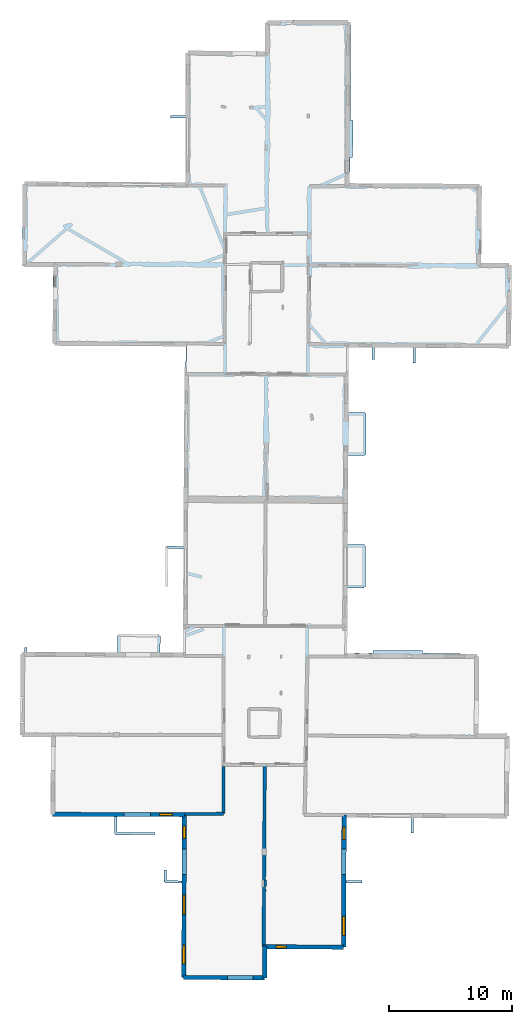
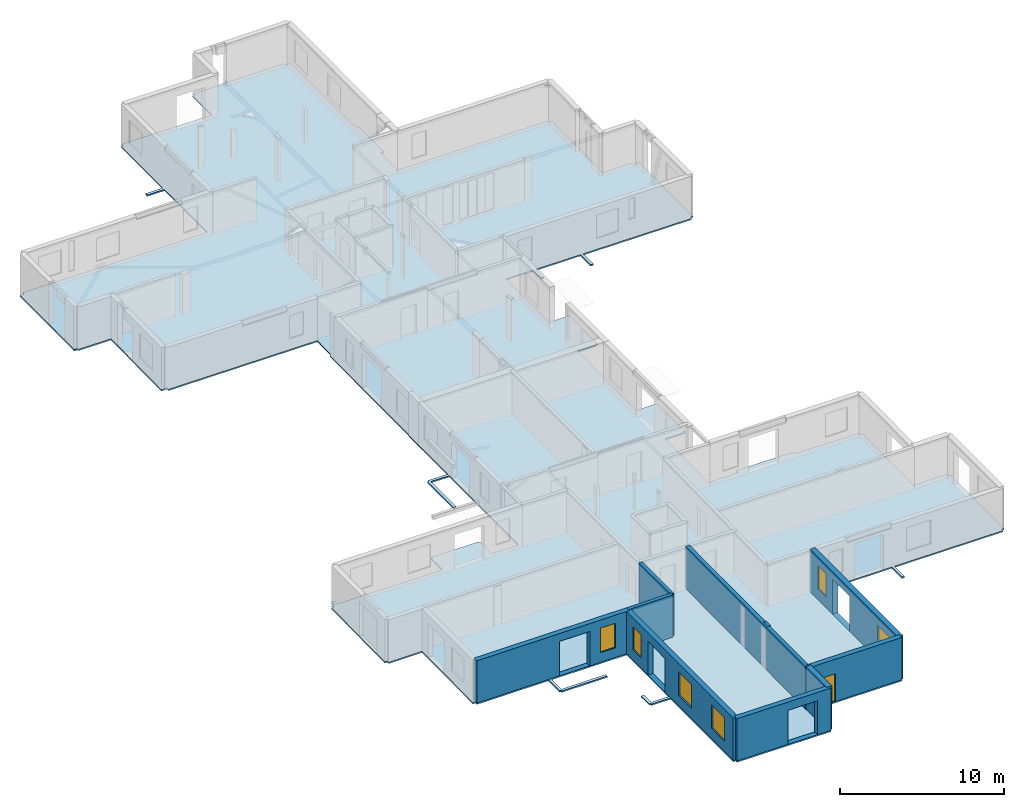
# One storey, part 2 of 14: 10 walls, 7 windows, 1 slab, 11 openings.
"""IFC2X3 building model written with IfcOpenShell, lengths in metres."""

from ifc_helpers import new_model, entity, si_unit, converted_unit, derived_unit, direction, frame, frame_2d, origin, origin_2d_with_axis, place, context, subcontext, project, spatial, polyline, rectangle, outline, extrude, source, transform, mapped, material, layer, layer_set, layer_usage, type_object, type_shapes, element, fill, save


model = new_model("IFC2X3")

# Units and contexts
model_context = context("Model", 3, precision=1e-05, world=origin(), true_north=direction((0.0, 1.0)))
body_context = subcontext(model_context, "Body", "Model", "MODEL_VIEW")
ifc_project = project(units=[si_unit("LENGTHUNIT", "METRE"), si_unit("AREAUNIT", "SQUARE_METRE"), si_unit("VOLUMEUNIT", "CUBIC_METRE"), converted_unit("PLANEANGLEUNIT", "DEGREE", entity("IfcRatioMeasure", 0.0174532925199433), si_unit("PLANEANGLEUNIT", "RADIAN"), dimensions=[0, 0, 0, 0, 0, 0, 0]), si_unit("MASSUNIT", "GRAM", prefix="KILO"), derived_unit("MASSDENSITYUNIT", [(si_unit("MASSUNIT", "GRAM", prefix="KILO"), 1), (si_unit("LENGTHUNIT", "METRE"), -3)]), derived_unit("MOMENTOFINERTIAUNIT", [(si_unit("LENGTHUNIT", "METRE"), 4)]), si_unit("TIMEUNIT", "SECOND"), si_unit("FREQUENCYUNIT", "HERTZ"), si_unit("THERMODYNAMICTEMPERATUREUNIT", "DEGREE_CELSIUS"), derived_unit("THERMALTRANSMITTANCEUNIT", [(si_unit("MASSUNIT", "GRAM", prefix="KILO"), 1), (si_unit("THERMODYNAMICTEMPERATUREUNIT", "KELVIN"), -1), (si_unit("TIMEUNIT", "SECOND"), -3)]), derived_unit("VOLUMETRICFLOWRATEUNIT", [(si_unit("LENGTHUNIT", "METRE"), 3), (si_unit("TIMEUNIT", "SECOND"), -1)]), si_unit("ELECTRICCURRENTUNIT", "AMPERE"), si_unit("ELECTRICVOLTAGEUNIT", "VOLT"), si_unit("POWERUNIT", "WATT"), si_unit("FORCEUNIT", "NEWTON", prefix="KILO"), si_unit("ILLUMINANCEUNIT", "LUX"), si_unit("LUMINOUSFLUXUNIT", "LUMEN"), si_unit("LUMINOUSINTENSITYUNIT", "CANDELA"), derived_unit("USERDEFINED", [(si_unit("MASSUNIT", "GRAM", prefix="KILO"), -1), (si_unit("LENGTHUNIT", "METRE"), -2), (si_unit("TIMEUNIT", "SECOND"), 3), (si_unit("LUMINOUSFLUXUNIT", "LUMEN"), 1)]), derived_unit("LINEARVELOCITYUNIT", [(si_unit("LENGTHUNIT", "METRE"), 1), (si_unit("TIMEUNIT", "SECOND"), -1)]), si_unit("PRESSUREUNIT", "PASCAL"), derived_unit("USERDEFINED", [(si_unit("LENGTHUNIT", "METRE"), -2), (si_unit("MASSUNIT", "GRAM", prefix="KILO"), 1), (si_unit("TIMEUNIT", "SECOND"), -2)]), derived_unit("LINEARFORCEUNIT", [(si_unit("MASSUNIT", "GRAM", prefix="KILO"), 1), (si_unit("LENGTHUNIT", "METRE"), 1), (si_unit("TIMEUNIT", "SECOND"), -2), (si_unit("LENGTHUNIT", "METRE"), -1)]), derived_unit("PLANARFORCEUNIT", [(si_unit("MASSUNIT", "GRAM", prefix="KILO"), 1), (si_unit("LENGTHUNIT", "METRE"), 1), (si_unit("TIMEUNIT", "SECOND"), -2), (si_unit("LENGTHUNIT", "METRE"), -2)])], contexts=[model_context])

# Site, building, storey
placement = place(None, origin())
site = spatial("IfcSite", under=ifc_project, at=placement, CompositionType="ELEMENT")
building = spatial("IfcBuilding", under=site, at=placement, CompositionType="ELEMENT")
storey_placement = place(placement, frame((0.0, 0.0, 8.83152770996094)))
storey = spatial("IfcBuildingStorey", under=building, at=storey_placement, Name="Level 4", CompositionType="ELEMENT", Elevation=8.83152770996094)

# Slab
ifc_material_1 = material(Name="Floor default")
ifc_layer_1 = layer(ifc_material_1, 0.1)
ifc_layer_set_1 = layer_set([ifc_layer_1], Name="Floor : 100mm")
ifc_layer_usage_1 = layer_usage(ifc_layer_set_1, "AXIS3", "POSITIVE", 0.0)
slab_type = type_object("IfcSlabType", Name="Floor : 100mm", PredefinedType="FLOOR")
slab_placement = place(storey_placement, origin())
element("IfcSlab", 1, at=slab_placement, inside=storey, type_object=slab_type, material=ifc_layer_usage_1, Name="Floor : 100mm", ObjectType="Floor : 100mm", PredefinedType="FLOOR", context=body_context, shape_type="SweptSolid", body=[
    extrude(outline(polyline([(-13.6808433532715, 19.4466152191162), (-13.5058479309082, 19.4453754425049), (-13.5059690475464, 19.2753753662109), (-11.161319732666, 19.2737121582031), (-11.2087287902832, 13.0091133117676), (-11.0337352752686, 13.0077896118164), (-11.0340738296509, 12.8327903747559), (-6.01071310043335, 12.8230762481689), (-6.01613569259644, 11.4494981765747), (-5.91613674163818, 11.4491033554077), (-5.91599750518799, 11.349102973938), (-2.7152214050293, 11.3535594940186), (-2.71549987792969, 11.5535593032837), (-5.81574058532715, 11.5492429733276), (-5.81071329116821, 12.8226900100708), (-0.506346702575684, 12.8124332427979), (-0.527259826660156, 7.61373710632324), (-1.77434730529785, 7.61762619018555), (-1.77778148651123, 8.5024995803833), (-1.97777938842773, 8.50172328948975), (-1.97396087646484, 7.51754903793335), (-1.87396144866943, 7.51793718338013), (-1.8742733001709, 7.41793775558472), (-0.528064727783203, 7.41373920440674), (-0.558828353881836, -0.233521282672882), (-0.383831024169922, -0.234224960207939), (-0.384821891784668, -0.409220635890961), (6.19634246826172, -0.446501553058624), (6.19733238220215, -0.271504580974579), (6.38232803344727, -0.270634293556213), (6.37127304077148, 2.07948136329651), (12.6121635437012, 2.04604291915894), (12.6131000518799, 2.22103953361511), (12.7981014251709, 2.22057437896729), (12.8112106323242, 7.43528461456299), (14.0985069274902, 7.44877481460571), (14.0964088439941, 7.64876365661621), (12.8117141723633, 7.63529968261719), (12.8245410919189, 12.7380781173706), (18.0702667236328, 12.7167844772339), (18.0606250762939, 11.4745321273804), (18.2606182098389, 11.4729804992676), (18.270263671875, 12.7159719467163), (25.8560485839844, 12.6851787567139), (25.8567581176758, 12.8601760864258), (26.0417556762695, 12.8593769073486), (26.0699653625488, 19.3851890563965), (25.8849601745605, 19.3859901428223), (25.883472442627, 19.5959796905518), (23.567928314209, 19.5795650482178), (23.6191291809082, 25.8393383026123), (23.434139251709, 25.8408508300781), (23.4348793029785, 26.0308494567871), (19.0079917907715, 26.1012115478516), (19.0089912414551, 26.3012084960938), (14.9984302520752, 26.3212242126465), (14.9974327087402, 26.1212272644043), (14.9063415527344, 26.0640850067139), (14.906623840332, 26.1127529144287), (14.6169090270996, 26.114429473877), (14.6166248321533, 26.0652141571045), (13.9065132141113, 26.0679817199707), (13.9076843261719, 26.1213703155518), (13.4927845001221, 26.1304683685303), (13.4914493560791, 26.0695991516113), (12.8926486968994, 26.0719318389893), (12.918212890625, 31.3962268829346), (14.2726745605469, 31.3939075469971), (14.2728462219238, 31.4939041137695), (14.3728446960449, 31.4936103820801), (14.3825721740723, 34.806941986084), (14.2825717926025, 34.8072357177734), (14.2824745178223, 34.9072303771973), (12.9350624084473, 34.9059066772461), (12.969820022583, 42.1449775695801), (14.3142108917236, 42.1357612609863), (14.3148956298828, 42.2357597351074), (14.4148941040039, 42.235179901123), (14.4341506958008, 45.5532913208008), (14.334156036377, 45.5538711547852), (14.3346786499023, 45.6538696289062), (12.9866981506348, 45.6609344482422), (13.0120239257812, 50.9353790283203), (14.9133644104004, 50.9244689941406), (14.9180450439453, 49.9465484619141), (15.1180438995361, 49.9475059509277), (15.1133728027344, 50.9233207702637), (18.2307548522949, 50.9054298400879), (18.2284202575684, 49.6575164794922), (18.4284172058105, 49.6571426391602), (18.4307556152344, 50.9042816162109), (26.0232582092285, 50.860710144043), (26.0242614746094, 51.0357055664062), (26.2092552185059, 51.0348663330078), (26.2296257019043, 55.5117607116699), (26.2391929626465, 55.5117721557617), (26.2391624450684, 57.6066780090332), (25.9246444702148, 57.6081085205078), (25.9245872497559, 57.6100463867188), (25.8246269226074, 57.6071891784668), (25.8243675231934, 57.7871894836426), (23.7627143859863, 57.7841873168945), (23.7853469848633, 59.7042503356934), (23.7997093200684, 59.7040176391602), (23.810131072998, 60.348934173584), (23.7922782897949, 60.3492240905762), (23.8318023681641, 64.03173828125), (23.6468124389648, 64.0337829589844), (23.6478157043457, 64.2087860107422), (13.0721950531006, 64.2694091796875), (13.1403465270996, 66.373046875), (13.3403434753418, 66.3718872070312), (13.3576850891113, 69.3722534179688), (13.1576881408691, 69.3734130859375), (13.1436767578125, 77.3448715209961), (12.8313293457031, 77.3465805053711), (12.8312301635742, 77.3489837646484), (12.731315612793, 77.3448257446289), (12.7304840087891, 77.5248260498047), (7.49785995483398, 77.5111999511719), (7.49782752990723, 77.5006484985352), (6.4023494720459, 77.4955673217773), (6.40318298339844, 77.3155975341797), (6.22318267822266, 77.3160171508789), (6.21767234802246, 74.9823303222656), (-0.0519886016845703, 75.0398864746094), (-0.0536870956420898, 74.8548889160156), (-0.228686332702637, 74.8552017211914), (-0.237639427185059, 69.7574844360352), (-1.4411678314209, 69.7714462280273), (-1.44348907470703, 69.5714569091797), (-0.237990379333496, 69.5574722290039), (-0.247166633605957, 64.3328018188477), (-13.1635856628418, 64.4022369384766), (-13.1645526885986, 64.2222595214844), (-13.2645263671875, 64.2245025634766), (-13.2645616531372, 64.2229232788086), (-13.4758968353271, 64.2232818603516), (-13.4872522354126, 57.5895805358887), (-13.3122501373291, 57.5892791748047), (-13.242335319519, 57.5091819763184), (-13.2423877716064, 57.4754981994629), (-10.9769954681396, 57.4719772338867), (-11.0390605926514, 51.2417030334473), (-10.7265567779541, 51.2385902404785), (-10.7265310287476, 51.2371101379395), (-10.6716957092285, 51.2380447387695), (-10.6716957092285, 51.2380447387695), (-10.6265449523926, 51.2388114929199), (-10.627368927002, 51.0688095092773), (-0.208054542541504, 51.0183219909668), (-0.223237037658691, 49.289436340332), (-0.321104049682617, 49.2899780273438), (-0.374987602233887, 39.5857467651367), (-0.401703834533691, 39.5858154296875), (-0.414438247680664, 34.7700653076172), (-1.78117370605469, 34.8041839599609), (-1.78366947174072, 34.704216003418), (-1.88366889953613, 34.704044342041), (-1.87823963165283, 31.527156829834), (-1.6782398223877, 31.5274982452393), (-1.68349361419678, 34.6016845703125), (-0.41496753692627, 34.5700187683105), (-0.437253952026367, 26.1418056488037), (-2.30625820159912, 26.1510925292969), (-2.27572822570801, 27.5110111236572), (-2.37570285797119, 27.5132541656494), (-2.37466335296631, 27.6132507324219), (-5.65986251831055, 27.6473922729492), (-5.66090106964111, 27.5473976135254), (-5.76089811325073, 27.5481357574463), (-5.77108335494995, 26.1683082580566), (-13.1139574050903, 26.2047939300537), (-13.1073513031006, 26.5616264343262), (-13.3073167800903, 26.5653285980225), (-13.3139724731445, 26.2057876586914), (-13.4583396911621, 26.2065048217773), (-13.4592590332031, 26.0215091705322), (-13.6342525482178, 26.0227489471436), (-13.6808433532715, 19.4466152191162)])), frame((0.0, 0.0, -0.1), z_axis=(0.0, 0.0, 1.0), x_axis=(1.0, 0.0, 0.0)), (0.0, 0.0, 1.0), 0.1),
])

# Walls
ifc_material_2 = material(Name="Default wall")
ifc_layer_2 = layer(ifc_material_2, 0.25)
ifc_layer_set_2 = layer_set([ifc_layer_2], Name="wall_thickness_0.2500")
ifc_layer_usage_2 = layer_usage(ifc_layer_set_2, "AXIS2", "POSITIVE", -0.125)
wall_type_1 = type_object("IfcWallType", Name="wall_thickness_0.2500", PredefinedType="STANDARD", material=ifc_layer_set_2)
wall_1_placement = place(storey_placement, frame((2.83207250697854, 16.9113386992605, 0.0), z_axis=(0.0, 0.0, 1.0), x_axis=(-0.000411140410926393, -0.999999915481778, 0.0)))
element("IfcWallStandardCase", 2, at=wall_1_placement, inside=storey, type_object=wall_type_1, material=ifc_layer_usage_2, Name="Wall:384", ObjectType="Wall", context=body_context, shape_type="SweptSolid", body=[
    extrude(outline(polyline([(3.85282739777768, -0.125), (3.85282739777768, 0.125), (0.0, 0.125), (0.0, -0.125), (3.85282739777768, -0.125)])), origin(), (0.0, 0.0, 1.0), 3.14668312072754),
])
wall_2_placement = place(storey_placement, frame((-0.330468789273721, 13.0305432023163, 0.0), z_axis=(0.0, 0.0, 1.0), x_axis=(0.999960850030092, 0.00884863871431233, 0.0)))
element("IfcWallStandardCase", 3, at=wall_2_placement, inside=storey, type_object=wall_type_1, material=ifc_layer_usage_2, Name="Wall:488", ObjectType="Wall", context=body_context, shape_type="SweptSolid", body=[
    extrude(outline(polyline([(3.16108145029731, -0.125), (3.16108145029731, 0.125), (0.0, 0.125), (0.0, -0.125), (3.16108145029731, -0.125)])), origin(), (0.0, 0.0, 1.0), 3.14668312072754),
])

# Wall, openings, window
ifc_layer_3 = layer(ifc_material_2, 0.349999994039536)
ifc_layer_set_3 = layer_set([ifc_layer_3], Name="wall_thickness_0.3500")
ifc_layer_usage_3 = layer_usage(ifc_layer_set_3, "AXIS2", "POSITIVE", -0.174999997019768)
wall_type_2 = type_object("IfcWallType", Name="wall_thickness_0.3500", PredefinedType="STANDARD", material=ifc_layer_set_3)
wall_3_placement = place(storey_placement, frame((-11.0337354364119, 13.0077900446039, 0.0), z_axis=(0.0, 0.0, 1.0), x_axis=(0.999998130395269, -0.00193370265731696, 0.0)))
wall_3 = element("IfcWallStandardCase", 4, at=wall_3_placement, inside=storey, type_object=wall_type_2, material=ifc_layer_usage_3, Name="Wall:399", ObjectType="Wall", context=body_context, shape_type="SweptSolid", body=[
    extrude(outline(polyline([(10.7031140161773, -0.174999997019768), (10.7031140161773, 0.174999997019768), (0.0, 0.174999997019768), (0.0, -0.174999997019768), (10.7031140161773, -0.174999997019768)])), origin(), (0.0, 0.0, 1.0), 3.14668312072754),
])
opening_1_placement = place(wall_3_placement, frame((5.80190456282029, -0.174999997019768, 0.00747203826904297)))
element("IfcOpeningElement", 5, at=opening_1_placement, cuts=wall_3, Name="Opening : 2135 x 2555 : 321", ObjectType="Opening", context=body_context, shape_type="SweptSolid", body=[
    extrude(rectangle(XDim=2.135, YDim=2.555, at=frame_2d((1.2775, 1.0675), x_axis=(0.0, 1.0))), frame((0.0, 0.0, 0.0), z_axis=(0.0, 1.0, 0.0), x_axis=(0.0, 0.0, 1.0)), (0.0, 0.0, 1.0), 0.349999994039536),
])
opening_2_placement = place(wall_3_placement, frame((8.67190456836425, -0.174999997019768, 0.727472305297852)))
opening_2 = element("IfcOpeningElement", 6, at=opening_2_placement, cuts=wall_3, Name="Opening : 1060 x 1820 : 322", ObjectType="Opening", context=body_context, shape_type="SweptSolid", body=[
    extrude(rectangle(XDim=1.06, YDim=1.82, at=frame_2d((0.91, 0.53), x_axis=(0.0, 1.0))), frame((0.0, 0.0, 0.0), z_axis=(0.0, 1.0, 0.0), x_axis=(0.0, 0.0, 1.0)), (0.0, 0.0, 1.0), 0.349999994039536),
])
ifc_material_3 = material(Name="Window Default")
window_style_1 = type_object("IfcWindowStyle", Name="Window : 1060 x 1820mm", ConstructionType="NOTDEFINED", OperationType="NOTDEFINED", ParameterTakesPrecedence=False, Sizeable=False, material=ifc_material_3)
shared_shape_1 = source(origin(), body_context, "Body", "SweptSolid", [
    extrude(rectangle(XDim=0.174999997019768, YDim=1.06, at=origin_2d_with_axis()), frame((0.53, 0.174999997019768, 0.0), z_axis=(0.0, 0.0, 1.0), x_axis=(0.0, 1.0, 0.0)), (0.0, 0.0, 1.0), 1.82),
])
type_shapes(window_style_1, [shared_shape_1])
window_1_placement = place(opening_2_placement, origin())
window_1 = element("IfcWindow", 7, at=window_1_placement, inside=storey, type_object=window_style_1, Name="Window : 1060 x 1820mm : 173", ObjectType="Window : 1060 x 1820mm", OverallHeight=1.82, OverallWidth=1.06, context=body_context, shape_type="MappedRepresentation", body=[
    mapped(shared_shape_1, transform((0.0, 0.0, 0.0), scale=1.0)),
])
fill(opening_2, window_1)

# Wall, opening, window
wall_4_placement = place(storey_placement, frame((6.11087243652118, 2.2558790807577, 0.0), z_axis=(0.0, 0.0, 1.0), x_axis=(0.999985646445507, -0.00535788232059737, 0.0)))
wall_4 = element("IfcWallStandardCase", 8, at=wall_4_placement, inside=storey, type_object=wall_type_2, material=ifc_layer_usage_3, Name="Wall:447", ObjectType="Wall", context=body_context, shape_type="SweptSolid", body=[
    extrude(outline(polyline([(6.50232206831158, -0.174999997019768), (6.50232206831158, 0.174999997019768), (0.0, 0.174999997019768), (0.0, -0.174999997019768), (6.50232206831158, -0.174999997019768)])), origin(), (0.0, 0.0, 1.0), 3.14668312072754),
])
opening_3_placement = place(wall_4_placement, frame((0.981664441855181, -0.174999997019768, 0.010472297668457)))
opening_3 = element("IfcOpeningElement", 9, at=opening_3_placement, cuts=wall_4, Name="Opening : 865 x 2050 : 346", ObjectType="Opening", context=body_context, shape_type="SweptSolid", body=[
    extrude(rectangle(XDim=0.865, YDim=2.05, at=frame_2d((1.025, 0.4325), x_axis=(0.0, 1.0))), frame((0.0, 0.0, 0.0), z_axis=(0.0, 1.0, 0.0), x_axis=(0.0, 0.0, 1.0)), (0.0, 0.0, 1.0), 0.349999994039536),
])
window_style_2 = type_object("IfcWindowStyle", Name="Window : 865 x 2050mm", ConstructionType="NOTDEFINED", OperationType="NOTDEFINED", ParameterTakesPrecedence=False, Sizeable=False, material=ifc_material_3)
shared_shape_2 = source(origin(), body_context, "Body", "SweptSolid", [
    extrude(rectangle(XDim=0.174999997019768, YDim=0.865, at=origin_2d_with_axis()), frame((0.4325, 0.174999997019768, 0.0), z_axis=(0.0, 0.0, 1.0), x_axis=(0.0, 1.0, 0.0)), (0.0, 0.0, 1.0), 2.05),
])
type_shapes(window_style_2, [shared_shape_2])
window_2_placement = place(opening_3_placement, origin())
window_2 = element("IfcWindow", 10, at=window_2_placement, inside=storey, type_object=window_style_2, Name="Window : 865 x 2050mm : 187", ObjectType="Window : 865 x 2050mm", OverallHeight=2.05, OverallWidth=0.865, context=body_context, shape_type="MappedRepresentation", body=[
    mapped(shared_shape_2, transform((0.0, 0.0, 0.0), scale=1.0)),
])
fill(opening_3, window_2)

# Wall, openings, windows
wall_5_placement = place(storey_placement, frame((-0.330468297379808, 13.030544109069, 0.0), z_axis=(0.0, 0.0, 1.0), x_axis=(-0.0040227691106814, -0.999991908631606, 0.0)))
wall_5 = element("IfcWallStandardCase", 11, at=wall_5_placement, inside=storey, type_object=wall_type_2, material=ifc_layer_usage_3, Name="Wall:449", ObjectType="Wall", context=body_context, shape_type="SweptSolid", body=[
    extrude(outline(polyline([(13.2648764083027, -0.174999997019768), (13.2648764083027, 0.174999997019768), (0.0, 0.174999997019768), (0.0, -0.174999997019768), (13.2648764083027, -0.174999997019768)])), origin(), (0.0, 0.0, 1.0), 3.14668312072754),
])
opening_4_placement = place(wall_5_placement, frame((2.82528493138051, -0.174999997019768, 0.00547218322753906)))
element("IfcOpeningElement", 12, at=opening_4_placement, cuts=wall_5, Name="Opening : 2075 x 2495 : 347", ObjectType="Opening", context=body_context, shape_type="SweptSolid", body=[
    extrude(rectangle(XDim=2.075, YDim=2.495, at=frame_2d((1.2475, 1.0375), x_axis=(0.0, 1.0))), frame((0.0, 0.0, 0.0), z_axis=(0.0, 1.0, 0.0), x_axis=(0.0, 0.0, 1.0)), (0.0, 0.0, 1.0), 0.349999994039536),
])
opening_5_placement = place(wall_5_placement, frame((6.59174435449387, -0.174999997019768, 0.78547191619873)))
opening_5 = element("IfcOpeningElement", 13, at=opening_5_placement, cuts=wall_5, Name="Opening : 1575 x 1730 : 348", ObjectType="Opening", context=body_context, shape_type="SweptSolid", body=[
    extrude(rectangle(XDim=1.575, YDim=1.73, at=frame_2d((0.865, 0.7875), x_axis=(0.0, 1.0))), frame((0.0, 0.0, 0.0), z_axis=(0.0, 1.0, 0.0), x_axis=(0.0, 0.0, 1.0)), (0.0, 0.0, 1.0), 0.349999994039536),
])
opening_6_placement = place(wall_5_placement, frame((10.6217447475411, -0.174999997019768, 0.790472030639648)))
opening_6 = element("IfcOpeningElement", 14, at=opening_6_placement, cuts=wall_5, Name="Opening : 1560 x 1725 : 349", ObjectType="Opening", context=body_context, shape_type="SweptSolid", body=[
    extrude(rectangle(XDim=1.56, YDim=1.725, at=frame_2d((0.8625, 0.78), x_axis=(0.0, 1.0))), frame((0.0, 0.0, 0.0), z_axis=(0.0, 1.0, 0.0), x_axis=(0.0, 0.0, 1.0)), (0.0, 0.0, 1.0), 0.349999994039536),
])
opening_7_placement = place(wall_5_placement, frame((0.984656673148678, -0.174999997019768, 0.770471572875977)))
opening_7 = element("IfcOpeningElement", 15, at=opening_7_placement, cuts=wall_5, Name="Opening : 990 x 1715 : 350", ObjectType="Opening", context=body_context, shape_type="SweptSolid", body=[
    extrude(rectangle(XDim=0.99, YDim=1.715, at=frame_2d((0.8575, 0.495), x_axis=(0.0, 1.0))), frame((0.0, 0.0, 0.0), z_axis=(0.0, 1.0, 0.0), x_axis=(0.0, 0.0, 1.0)), (0.0, 0.0, 1.0), 0.349999994039536),
])
window_style_3 = type_object("IfcWindowStyle", Name="Window : 1575 x 1730mm", ConstructionType="NOTDEFINED", OperationType="NOTDEFINED", ParameterTakesPrecedence=False, Sizeable=False, material=ifc_material_3)
shared_shape_3 = source(origin(), body_context, "Body", "SweptSolid", [
    extrude(rectangle(XDim=0.174999997019768, YDim=1.575, at=origin_2d_with_axis()), frame((0.7875, 0.174999997019768, 0.0), z_axis=(0.0, 0.0, 1.0), x_axis=(0.0, 1.0, 0.0)), (0.0, 0.0, 1.0), 1.73),
])
type_shapes(window_style_3, [shared_shape_3])
window_3_placement = place(opening_5_placement, origin())
window_3 = element("IfcWindow", 16, at=window_3_placement, inside=storey, type_object=window_style_3, Name="Window : 1575 x 1730mm : 188", ObjectType="Window : 1575 x 1730mm", OverallHeight=1.73, OverallWidth=1.575, context=body_context, shape_type="MappedRepresentation", body=[
    mapped(shared_shape_3, transform((0.0, 0.0, 0.0), scale=1.0)),
])
fill(opening_5, window_3)
window_style_4 = type_object("IfcWindowStyle", Name="Window : 1560 x 1725mm", ConstructionType="NOTDEFINED", OperationType="NOTDEFINED", ParameterTakesPrecedence=False, Sizeable=False, material=ifc_material_3)
shared_shape_4 = source(origin(), body_context, "Body", "SweptSolid", [
    extrude(rectangle(XDim=0.174999997019768, YDim=1.56, at=origin_2d_with_axis()), frame((0.78, 0.174999997019768, 0.0), z_axis=(0.0, 0.0, 1.0), x_axis=(0.0, 1.0, 0.0)), (0.0, 0.0, 1.0), 1.725),
])
type_shapes(window_style_4, [shared_shape_4])
window_4_placement = place(opening_6_placement, origin())
window_4 = element("IfcWindow", 17, at=window_4_placement, inside=storey, type_object=window_style_4, Name="Window : 1560 x 1725mm : 189", ObjectType="Window : 1560 x 1725mm", OverallHeight=1.725, OverallWidth=1.56, context=body_context, shape_type="MappedRepresentation", body=[
    mapped(shared_shape_4, transform((0.0, 0.0, 0.0), scale=1.0)),
])
fill(opening_6, window_4)
window_style_5 = type_object("IfcWindowStyle", Name="Window : 990 x 1715mm", ConstructionType="NOTDEFINED", OperationType="NOTDEFINED", ParameterTakesPrecedence=False, Sizeable=False, material=ifc_material_3)
shared_shape_5 = source(origin(), body_context, "Body", "SweptSolid", [
    extrude(rectangle(XDim=0.174999997019768, YDim=0.99, at=origin_2d_with_axis()), frame((0.495, 0.174999997019768, 0.0), z_axis=(0.0, 0.0, 1.0), x_axis=(0.0, 1.0, 0.0)), (0.0, 0.0, 1.0), 1.715),
])
type_shapes(window_style_5, [shared_shape_5])
window_5_placement = place(opening_7_placement, origin())
window_5 = element("IfcWindow", 18, at=window_5_placement, inside=storey, type_object=window_style_5, Name="Window : 990 x 1715mm : 190", ObjectType="Window : 990 x 1715mm", OverallHeight=1.715, OverallWidth=0.99, context=body_context, shape_type="MappedRepresentation", body=[
    mapped(shared_shape_5, transform((0.0, 0.0, 0.0), scale=1.0)),
])
fill(opening_7, window_5)

# Wall, opening
wall_6_placement = place(storey_placement, frame((-0.38383080881846, -0.234223446659731, 0.0), z_axis=(0.0, 0.0, 1.0), x_axis=(0.999983955457111, -0.00566470019962177, 0.0)))
wall_6 = element("IfcWallStandardCase", 19, at=wall_6_placement, inside=storey, type_object=wall_type_2, material=ifc_layer_usage_3, Name="Wall:456", ObjectType="Wall", context=body_context, shape_type="SweptSolid", body=[
    extrude(outline(polyline([(6.58126923824721, -0.174999997019768), (6.58126923824721, 0.174999997019768), (0.0, 0.174999997019768), (0.0, -0.174999997019768), (6.58126923824721, -0.174999997019768)])), origin(), (0.0, 0.0, 1.0), 3.14668312072754),
])
opening_8_placement = place(wall_6_placement, frame((3.56932358840003, -0.174999997019768, 0.00647258758544922)))
element("IfcOpeningElement", 20, at=opening_8_placement, cuts=wall_6, Name="Opening : 2065 x 2525 : 352", ObjectType="Opening", context=body_context, shape_type="SweptSolid", body=[
    extrude(rectangle(XDim=2.065, YDim=2.525, at=frame_2d((1.2625, 1.0325), x_axis=(0.0, 1.0))), frame((0.0, 0.0, 0.0), z_axis=(0.0, 1.0, 0.0), x_axis=(0.0, 0.0, 1.0)), (0.0, 0.0, 1.0), 0.349999994039536),
])

# Walls
ifc_layer_4 = layer(ifc_material_2, 0.2)
ifc_layer_set_4 = layer_set([ifc_layer_4], Name="wall_thickness_0.2000")
ifc_layer_usage_4 = layer_usage(ifc_layer_set_4, "AXIS2", "POSITIVE", -0.1)
wall_type_3 = type_object("IfcWallType", Name="wall_thickness_0.2000", PredefinedType="STANDARD", material=ifc_layer_set_4)
wall_7_placement = place(storey_placement, frame((6.23696928499333, 7.66625125078873, 0.0), z_axis=(0.0, 0.0, 1.0), x_axis=(0.00277927829462806, -0.999996137798622, 0.0)))
element("IfcWallStandardCase", 21, at=wall_7_placement, inside=storey, type_object=wall_type_3, material=ifc_layer_usage_4, Name="Wall:485", ObjectType="Wall", context=body_context, shape_type="SweptSolid", body=[
    extrude(outline(polyline([(0.525000215675355, -0.1), (0.525000215675355, 0.1), (0.0, 0.1), (0.0, -0.1), (0.525000215675355, -0.1)])), origin(), (0.0, 0.0, 1.0), 3.14668312072754),
])
ifc_layer_5 = layer(ifc_material_2, 0.370000004768372)
ifc_layer_set_5 = layer_set([ifc_layer_5], Name="wall_thickness_0.3700")
ifc_layer_usage_5 = layer_usage(ifc_layer_set_5, "AXIS2", "POSITIVE", -0.185000002384186)
wall_type_4 = type_object("IfcWallType", Name="wall_thickness_0.3700", PredefinedType="STANDARD", material=ifc_layer_set_5)
wall_8_placement = place(storey_placement, frame((6.18513973622145, 2.31992809498125, 0.0), z_axis=(0.0, 0.0, 1.0), x_axis=(0.00470422555838898, -0.999988935069732, 0.0)))
element("IfcWallStandardCase", 22, at=wall_8_placement, inside=storey, type_object=wall_type_4, material=ifc_layer_usage_5, Name="Wall:448", ObjectType="Wall", context=body_context, shape_type="SweptSolid", body=[
    extrude(outline(polyline([(2.59146136495972, -0.185000002384186), (2.59146136495972, 0.185000002384186), (0.0, 0.185000002384186), (0.0, -0.185000002384186), (2.59146136495972, -0.185000002384186)])), origin(), (0.0, 0.0, 1.0), 3.14668312072754),
])

# Wall, openings, windows
wall_9_placement = place(storey_placement, frame((12.6400871758955, 12.9553296049485, 0.0), z_axis=(0.0, 0.0, 1.0), x_axis=(-0.0025139140900583, -0.999996840112981, 0.0)))
wall_9 = element("IfcWallStandardCase", 23, at=wall_9_placement, inside=storey, type_object=wall_type_4, material=ifc_layer_usage_5, Name="Wall:473", ObjectType="Wall", context=body_context, shape_type="SweptSolid", body=[
    extrude(outline(polyline([(10.734324042237, -0.185000002384186), (10.734324042237, 0.185000002384186), (0.0, 0.185000002384186), (0.0, -0.185000002384186), (10.734324042237, -0.185000002384186)])), origin(), (0.0, 0.0, 1.0), 3.14668312072754),
])
opening_9_placement = place(wall_9_placement, frame((2.76431006430858, -0.185000002384186, 0.00547218322753906)))
element("IfcOpeningElement", 24, at=opening_9_placement, cuts=wall_9, Name="Opening : 2080 x 2600 : 365", ObjectType="Opening", context=body_context, shape_type="SweptSolid", body=[
    extrude(rectangle(XDim=2.08, YDim=2.6, at=frame_2d((1.3, 1.04), x_axis=(0.0, 1.0))), frame((0.0, 0.0, 0.0), z_axis=(0.0, 1.0, 0.0), x_axis=(0.0, 0.0, 1.0)), (0.0, 0.0, 1.0), 0.370000004768372),
])
opening_10_placement = place(wall_9_placement, frame((8.25434244475916, -0.185000002384186, 0.815471649169922)))
opening_10 = element("IfcOpeningElement", 25, at=opening_10_placement, cuts=wall_9, Name="Opening : 1540 x 1710 : 366", ObjectType="Opening", context=body_context, shape_type="SweptSolid", body=[
    extrude(rectangle(XDim=1.54, YDim=1.71, at=frame_2d((0.855, 0.77), x_axis=(0.0, 1.0))), frame((0.0, 0.0, 0.0), z_axis=(0.0, 1.0, 0.0), x_axis=(0.0, 0.0, 1.0)), (0.0, 0.0, 1.0), 0.370000004768372),
])
opening_11_placement = place(wall_9_placement, frame((0.979342724119242, -0.185000002384186, 0.805472373962402)))
opening_11 = element("IfcOpeningElement", 26, at=opening_11_placement, cuts=wall_9, Name="Opening : 1005 x 1725 : 367", ObjectType="Opening", context=body_context, shape_type="SweptSolid", body=[
    extrude(rectangle(XDim=1.005, YDim=1.725, at=frame_2d((0.8625, 0.5025), x_axis=(0.0, 1.0))), frame((0.0, 0.0, 0.0), z_axis=(0.0, 1.0, 0.0), x_axis=(0.0, 0.0, 1.0)), (0.0, 0.0, 1.0), 0.370000004768372),
])
window_style_6 = type_object("IfcWindowStyle", Name="Window : 1005 x 1725mm", ConstructionType="NOTDEFINED", OperationType="NOTDEFINED", ParameterTakesPrecedence=False, Sizeable=False, material=ifc_material_3)
shared_shape_6 = source(origin(), body_context, "Body", "SweptSolid", [
    extrude(rectangle(XDim=0.170000001788139, YDim=1.005, at=origin_2d_with_axis()), frame((0.5025, 0.170000001788139, 0.0), z_axis=(0.0, 0.0, 1.0), x_axis=(0.0, 1.0, 0.0)), (0.0, 0.0, 1.0), 1.725),
])
type_shapes(window_style_6, [shared_shape_6])
window_6_placement = place(opening_11_placement, origin())
window_6 = element("IfcWindow", 27, at=window_6_placement, inside=storey, type_object=window_style_6, Name="Window : 1005 x 1725mm : 199", ObjectType="Window : 1005 x 1725mm", OverallHeight=1.725, OverallWidth=1.005, context=body_context, shape_type="MappedRepresentation", body=[
    mapped(shared_shape_6, transform((0.0, 0.0, 0.0), scale=1.0)),
])
fill(opening_11, window_6)
window_style_7 = type_object("IfcWindowStyle", Name="Window : 1540 x 1710mm", ConstructionType="NOTDEFINED", OperationType="NOTDEFINED", ParameterTakesPrecedence=False, Sizeable=False, material=ifc_material_3)
shared_shape_7 = source(origin(), body_context, "Body", "SweptSolid", [
    extrude(rectangle(XDim=0.189999997615814, YDim=1.54, at=origin_2d_with_axis()), frame((0.77, 0.189999997615814, 0.0), z_axis=(0.0, 0.0, 1.0), x_axis=(0.0, 1.0, 0.0)), (0.0, 0.0, 1.0), 1.71),
])
type_shapes(window_style_7, [shared_shape_7])
window_7_placement = place(opening_10_placement, origin())
window_7 = element("IfcWindow", 28, at=window_7_placement, inside=storey, type_object=window_style_7, Name="Window : 1540 x 1710mm : 198", ObjectType="Window : 1540 x 1710mm", OverallHeight=1.71, OverallWidth=1.54, context=body_context, shape_type="MappedRepresentation", body=[
    mapped(shared_shape_7, transform((0.0, 0.0, 0.0), scale=1.0)),
])
fill(opening_10, window_7)

# Wall
ifc_layer_6 = layer(ifc_material_2, 0.270000010728836)
ifc_layer_set_6 = layer_set([ifc_layer_6], Name="wall_thickness_0.2700")
ifc_layer_usage_6 = layer_usage(ifc_layer_set_6, "AXIS2", "POSITIVE", -0.135000005364418)
wall_type_5 = type_object("IfcWallType", Name="wall_thickness_0.2700", PredefinedType="STANDARD", material=ifc_layer_set_6)
wall_10_placement = place(storey_placement, frame((6.19710507296738, 17.0192745274838, 0.0), z_axis=(0.0, 0.0, 1.0), x_axis=(-0.00584078094551672, -0.999982942493494, 0.0)))
element("IfcWallStandardCase", 29, at=wall_10_placement, inside=storey, type_object=wall_type_5, material=ifc_layer_usage_6, Name="Wall:407", ObjectType="Wall", context=body_context, shape_type="SweptSolid", body=[
    extrude(outline(polyline([(14.7636476173007, -0.135000005364418), (14.7636476173007, 0.135000005364418), (0.0, 0.135000005364418), (0.0, -0.135000005364418), (14.7636476173007, -0.135000005364418)])), origin(), (0.0, 0.0, 1.0), 3.14668312072754),
])

save(model, "model.ifc")
